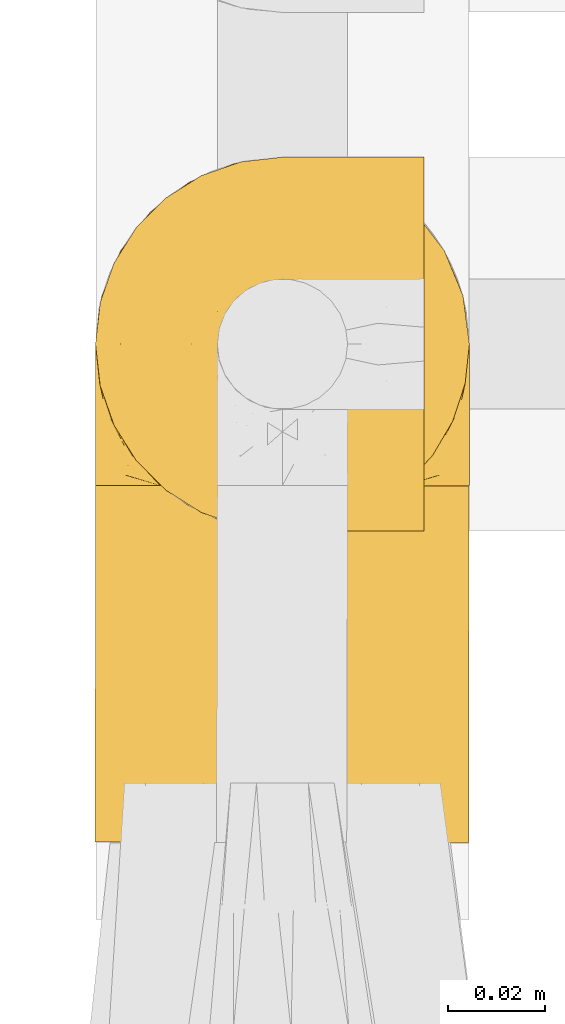
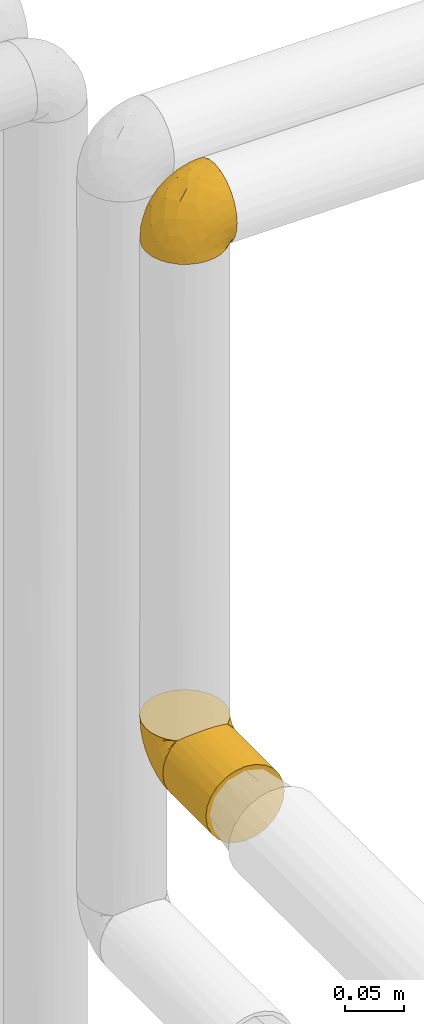
# One storey, part 76 of 827: 3 coverings.
"""IFC2X3 building model written with IfcOpenShell, lengths in millimetres."""

from ifc_helpers import new_model, entity, si_unit, converted_unit, derived_unit, direction, frame, origin, place, context, subcontext, project, spatial, faceted_brep, element, save


model = new_model("IFC2X3")

# Units and contexts
model_context = context("Model", 3, precision=0.01, world=origin(), true_north=direction((6.12303176911189e-17, 1.0)))
body_context = subcontext(model_context, "Body", "Model", "MODEL_VIEW")
ifc_project = project(units=[si_unit("LENGTHUNIT", "METRE", prefix="MILLI"), si_unit("AREAUNIT", "SQUARE_METRE"), si_unit("VOLUMEUNIT", "CUBIC_METRE"), converted_unit("PLANEANGLEUNIT", "DEGREE", entity("IfcRatioMeasure", 0.0174532925199433), si_unit("PLANEANGLEUNIT", "RADIAN"), dimensions=[0, 0, 0, 0, 0, 0, 0]), si_unit("MASSUNIT", "GRAM", prefix="KILO"), derived_unit("MASSDENSITYUNIT", [(si_unit("MASSUNIT", "GRAM", prefix="KILO"), 1), (si_unit("LENGTHUNIT", "METRE"), -3)]), derived_unit("MOMENTOFINERTIAUNIT", [(si_unit("LENGTHUNIT", "METRE"), 4)]), si_unit("TIMEUNIT", "SECOND"), si_unit("FREQUENCYUNIT", "HERTZ"), si_unit("THERMODYNAMICTEMPERATUREUNIT", "DEGREE_CELSIUS"), derived_unit("THERMALTRANSMITTANCEUNIT", [(si_unit("MASSUNIT", "GRAM", prefix="KILO"), 1), (si_unit("THERMODYNAMICTEMPERATUREUNIT", "KELVIN"), -1), (si_unit("TIMEUNIT", "SECOND"), -3)]), derived_unit("VOLUMETRICFLOWRATEUNIT", [(si_unit("LENGTHUNIT", "METRE"), 3), (si_unit("TIMEUNIT", "SECOND"), -1)]), derived_unit("MASSFLOWRATEUNIT", [(si_unit("MASSUNIT", "GRAM", prefix="KILO"), 1), (si_unit("TIMEUNIT", "SECOND"), -1)]), derived_unit("ROTATIONALFREQUENCYUNIT", [(si_unit("TIMEUNIT", "SECOND"), -1)]), si_unit("ELECTRICCURRENTUNIT", "AMPERE"), si_unit("ELECTRICVOLTAGEUNIT", "VOLT"), si_unit("POWERUNIT", "WATT"), si_unit("FORCEUNIT", "NEWTON", prefix="KILO"), si_unit("ILLUMINANCEUNIT", "LUX"), si_unit("LUMINOUSFLUXUNIT", "LUMEN"), si_unit("LUMINOUSINTENSITYUNIT", "CANDELA"), derived_unit("USERDEFINED", [(si_unit("MASSUNIT", "GRAM", prefix="KILO"), -1), (si_unit("LENGTHUNIT", "METRE"), -2), (si_unit("TIMEUNIT", "SECOND"), 3), (si_unit("LUMINOUSFLUXUNIT", "LUMEN"), 1)]), derived_unit("LINEARVELOCITYUNIT", [(si_unit("LENGTHUNIT", "METRE"), 1), (si_unit("TIMEUNIT", "SECOND"), -1)]), si_unit("PRESSUREUNIT", "PASCAL"), derived_unit("USERDEFINED", [(si_unit("LENGTHUNIT", "METRE"), -2), (si_unit("MASSUNIT", "GRAM", prefix="KILO"), 1), (si_unit("TIMEUNIT", "SECOND"), -2)]), derived_unit("LINEARFORCEUNIT", [(si_unit("MASSUNIT", "GRAM", prefix="KILO"), 1), (si_unit("LENGTHUNIT", "METRE"), 1), (si_unit("TIMEUNIT", "SECOND"), -2), (si_unit("LENGTHUNIT", "METRE"), -1)]), derived_unit("PLANARFORCEUNIT", [(si_unit("MASSUNIT", "GRAM", prefix="KILO"), 1), (si_unit("LENGTHUNIT", "METRE"), 1), (si_unit("TIMEUNIT", "SECOND"), -2), (si_unit("LENGTHUNIT", "METRE"), -2)])], contexts=[model_context])

# Site, building, storey
site_placement = place(None, origin())
site = spatial("IfcSite", under=ifc_project, at=site_placement, CompositionType="ELEMENT")
building_placement = place(site_placement, origin())
building = spatial("IfcBuilding", under=site, at=building_placement, CompositionType="ELEMENT")
storey_placement = place(building_placement, frame((0.0, 0.0, 28200.0)))
storey = spatial("IfcBuildingStorey", under=building, at=storey_placement, Name="08", CompositionType="ELEMENT", Elevation=28200.0)

# Coverings
covering_1_placement = place(storey_placement, frame((17886.68, 11719.47, 1869.3)))
element("IfcCovering", 1, at=covering_1_placement, inside=storey, Name=":ADSK_", ObjectType=":ADSK_", PredefinedType="INSULATION", context=body_context, shape_type="Brep", body=[
    faceted_brep([(23.36, 5.41, 1.6), (16.07, 9.99, 1.6), (9.98, 16.08, 1.6), (5.4, 23.37, 1.6), (2.56, 31.49, 1.6), (1.6, 40.05, 1.6), (2.56, 48.61, 1.6), (5.41, 56.73, 1.6), (9.99, 64.02, 1.6), (16.08, 70.11, 1.6), (23.37, 74.69, 1.6), (31.49, 77.53, 1.6), (40.05, 78.5, 1.6), (48.15, 77.63, 1.6), (55.88, 75.08, 1.6), (62.9, 70.97, 1.6), (68.89, 65.47, 1.6), (68.89, 63.27, 1.6), (68.89, 61.53, 1.6), (68.89, 59.57, 1.6), (68.89, 57.6, 1.6), (68.89, 55.63, 1.6), (68.89, 53.67, 1.6), (68.89, 51.7, 1.6), (68.89, 49.73, 1.6), (68.89, 47.54, 1.6), (68.89, 45.34, 1.6), (68.89, 43.15, 1.6), (68.89, 40.96, 1.6), (68.89, 38.76, 1.6), (68.89, 36.57, 1.6), (68.89, 34.37, 1.6), (68.89, 32.18, 1.6), (68.89, 29.98, 1.6), (68.89, 27.79, 1.6), (68.89, 25.6, 1.6), (68.89, 23.4, 1.6), (68.89, 21.21, 1.6), (68.89, 19.01, 1.6), (68.89, 16.82, 1.6), (68.89, 14.62, 1.6), (62.89, 9.12, 1.6), (55.86, 5.0, 1.6), (48.13, 2.46, 1.6), (40.05, 1.6, 1.6), (31.49, 2.56, 1.6), (69.15, 65.47, 1.85), (69.15, 70.97, 7.85), (69.15, 75.09, 14.87), (69.15, 77.63, 22.6), (69.15, 78.5, 30.7), (69.15, 77.19, 40.65), (69.15, 73.34, 49.92), (69.15, 67.23, 57.88), (69.15, 59.27, 63.99), (69.15, 50.0, 67.84), (69.15, 40.05, 69.15), (69.15, 30.09, 67.84), (69.15, 20.82, 63.99), (69.15, 12.86, 57.88), (69.15, 6.75, 49.92), (69.15, 2.91, 40.65), (69.15, 1.6, 30.7), (69.15, 2.46, 22.6), (69.15, 5.0, 14.87), (69.15, 9.12, 7.85), (69.15, 14.62, 1.85), (69.15, 16.82, 1.85), (69.15, 17.8, 1.85), (69.15, 19.39, 1.85), (69.15, 20.98, 1.85), (69.15, 22.57, 1.85), (69.15, 24.16, 1.85), (69.15, 25.75, 1.85), (69.15, 27.33, 1.85), (69.15, 28.92, 1.85), (69.15, 30.51, 1.85), (69.15, 32.1, 1.85), (69.15, 33.69, 1.85), (69.15, 35.28, 1.85), (69.15, 36.87, 1.85), (69.15, 38.46, 1.85), (69.15, 40.05, 1.85), (69.15, 41.63, 1.85), (69.15, 43.22, 1.85), (69.15, 44.81, 1.85), (69.15, 46.4, 1.85), (69.15, 47.99, 1.85), (69.15, 49.58, 1.85), (69.15, 51.17, 1.85), (69.15, 52.76, 1.85), (69.15, 54.72, 1.85), (69.15, 56.69, 1.85), (69.15, 58.88, 1.85), (69.15, 61.08, 1.85), (69.15, 63.27, 1.85), (68.96, 37.77, 1.77), (68.97, 36.07, 1.78), (68.97, 32.96, 1.77), (68.97, 31.36, 1.77), (68.95, 56.52, 1.76), (68.96, 54.96, 1.77), (68.98, 18.75, 1.79), (68.97, 58.07, 1.78), (68.97, 50.37, 1.78), (68.98, 23.36, 1.78), (68.97, 24.95, 1.78), (68.97, 42.43, 1.78), (68.94, 15.97, 1.74), (68.98, 51.96, 1.78), (68.98, 53.47, 1.78), (68.96, 48.63, 1.77), (68.97, 63.93, 1.78), (68.98, 40.93, 1.78), (68.98, 29.72, 1.78), (68.97, 62.4, 1.77), (68.96, 60.92, 1.77), (68.97, 17.31, 1.77), (68.97, 21.74, 1.78), (68.98, 34.56, 1.78), (68.96, 20.18, 1.77), (68.97, 14.62, 1.77), (68.94, 14.62, 1.72), (68.92, 14.62, 1.66), (68.97, 65.47, 1.77), (69.02, 65.47, 1.8), (69.08, 65.47, 1.82), (68.98, 59.5, 1.79), (68.97, 47.1, 1.78), (68.98, 45.61, 1.79), (68.97, 28.18, 1.78), (69.08, 14.62, 1.82), (69.02, 14.62, 1.8), (68.96, 26.61, 1.76), (68.92, 65.47, 1.66), (68.94, 65.47, 1.72), (68.97, 39.32, 1.78), (68.96, 44.12, 1.77), (67.02, 72.26, 9.41), (63.33, 76.57, 17.65), (64.61, 71.77, 7.41), (49.27, 78.5, 21.47), (51.4, 77.9, 15.21), (43.94, 78.5, 16.15), (61.87, 78.5, 28.75), (61.54, 75.52, 13.67), (57.95, 76.13, 12.79), (56.12, 77.81, 19.18), (63.4, 78.5, 29.16), (65.41, 72.4, 9.04), (53.1, 76.56, 7.41), (63.04, 71.77, 5.74), (61.33, 72.25, 3.72), (41.99, 78.5, 8.87), (54.6, 78.5, 26.8), (56.6, 75.75, 9.53), (41.58, 78.5, 7.34), (13.72, 50.46, 37.63), (5.82, 52.75, 17.92), (6.74, 40.05, 27.45), (58.82, 77.7, 37.01), (51.58, 77.66, 34.22), (42.09, 71.02, 45.87), (46.12, 63.45, 56.57), (55.56, 70.55, 52.31), (52.38, 75.57, 42.07), (61.54, 75.57, 44.74), (23.76, 72.61, 21.49), (20.5, 72.61, 11.02), (14.64, 67.24, 15.64), (41.77, 77.74, 26.02), (16.28, 57.43, 36.59), (49.4, 47.19, 65.49), (52.34, 54.76, 63.99), (4.3, 40.05, 15.2), (58.67, 63.45, 60.27), (25.26, 60.1, 45.25), (20.17, 63.72, 35.21), (34.7, 76.83, 22.52), (28.67, 76.34, 12.03), (8.62, 60.51, 13.32), (33.37, 72.59, 35.9), (41.35, 76.05, 33.87), (17.15, 66.15, 25.73), (12.68, 60.51, 26.34), (21.47, 51.88, 46.78), (41.11, 55.34, 59.54), (37.53, 48.67, 60.18), (30.64, 53.89, 53.93), (26.66, 46.73, 53.36), (21.38, 40.05, 49.36), (14.06, 40.05, 38.4), (55.54, 40.05, 66.44), (35.17, 63.95, 50.09), (29.04, 67.24, 41.08), (24.34, 69.62, 31.14), (29.33, 73.6, 28.19), (43.3, 40.05, 64.0), (32.34, 40.05, 56.68), (57.75, 4.52, 43.9), (49.41, 32.72, 65.46), (27.85, 27.18, 52.22), (13.7, 29.63, 37.61), (14.63, 12.86, 15.64), (8.61, 19.59, 13.31), (48.85, 9.54, 50.02), (54.13, 16.64, 59.28), (37.84, 17.48, 53.05), (23.75, 7.49, 21.48), (20.49, 7.49, 11.01), (28.66, 3.75, 12.03), (20.83, 20.75, 41.02), (55.15, 2.33, 35.39), (54.6, 1.6, 26.8), (61.87, 1.6, 28.75), (41.58, 1.6, 7.34), (57.58, 26.94, 65.81), (59.91, 9.54, 53.28), (36.94, 31.21, 59.8), (45.72, 25.33, 61.82), (5.82, 27.35, 17.91), (37.91, 8.17, 41.4), (50.18, 4.3, 40.48), (12.67, 19.59, 26.34), (49.29, 2.23, 31.68), (42.64, 2.45, 27.68), (43.94, 1.6, 16.15), (49.27, 1.6, 21.47), (19.45, 12.86, 28.05), (34.7, 3.27, 22.54), (41.99, 1.6, 8.87), (62.29, 2.29, 37.3), (29.01, 12.86, 41.07), (31.47, 6.89, 32.24), (37.18, 12.43, 47.4), (43.45, 4.1, 35.77), (63.33, 3.53, 17.65), (67.23, 6.88, 11.06), (66.07, 8.16, 8.55), (65.22, 9.02, 6.63), (61.99, 5.0, 12.77), (57.95, 3.96, 12.79), (53.09, 3.52, 7.41), (56.84, 2.4, 18.97), (61.33, 7.83, 3.72), (63.06, 8.32, 5.76), (51.41, 2.19, 15.21), (56.61, 4.34, 9.52)], [[[0, 1, 2, 3, 4, 5, 6, 7, 8, 9, 10, 11, 12, 13, 14, 15, 16, 17, 18, 19, 20, 21, 22, 23, 24, 25, 26, 27, 28, 29, 30, 31, 32, 33, 34, 35, 36, 37, 38, 39, 40, 41, 42, 43, 44, 45]], [[46, 47, 48, 49, 50, 51, 52, 53, 54, 55, 56, 57, 58, 59, 60, 61, 62, 63, 64, 65, 66, 67, 68, 69, 70, 71, 72, 73, 74, 75, 76, 77, 78, 79, 80, 81, 82, 83, 84, 85, 86, 87, 88, 89, 90, 91, 92, 93, 94, 95]], [[96, 97, 30]], [[98, 77, 99]], [[100, 101, 21]], [[69, 68, 102]], [[20, 19, 103]], [[24, 23, 104]], [[20, 103, 100]], [[72, 105, 106]], [[84, 83, 107]], [[89, 88, 104]], [[108, 67, 66]], [[109, 110, 90]], [[111, 25, 24]], [[112, 17, 16]], [[82, 113, 83]], [[109, 23, 22]], [[114, 76, 75]], [[105, 36, 106]], [[104, 111, 24]], [[18, 115, 116]], [[97, 96, 80]], [[67, 108, 117]], [[105, 71, 118]], [[31, 97, 119]], [[102, 120, 69]], [[108, 121, 122, 123, 40]], [[112, 95, 115]], [[17, 115, 18]], [[94, 116, 115]], [[117, 68, 67]], [[38, 117, 39]], [[112, 124, 125, 126, 46]], [[17, 112, 115]], [[70, 120, 118]], [[39, 117, 108]], [[120, 38, 37]], [[120, 37, 118]], [[120, 70, 69]], [[116, 94, 127]], [[128, 86, 129]], [[117, 38, 102]], [[74, 130, 75]], [[99, 33, 32]], [[115, 95, 94]], [[39, 108, 40]], [[108, 66, 131, 132, 121]], [[105, 72, 71]], [[118, 37, 36]], [[71, 70, 118]], [[35, 106, 36]], [[36, 105, 118]], [[35, 133, 106]], [[74, 73, 133]], [[106, 133, 73]], [[99, 114, 33]], [[133, 35, 34]], [[73, 72, 106]], [[95, 112, 46]], [[112, 16, 134, 135, 124]], [[130, 114, 75]], [[99, 76, 114]], [[114, 130, 33]], [[34, 33, 130]], [[78, 77, 98]], [[98, 119, 78]], [[130, 133, 34]], [[133, 130, 74]], [[79, 97, 80]], [[98, 99, 32]], [[98, 32, 31]], [[77, 76, 99]], [[97, 79, 119]], [[136, 96, 29]], [[30, 97, 31]], [[136, 29, 28]], [[81, 80, 96]], [[29, 96, 30]], [[31, 119, 98]], [[119, 79, 78]], [[96, 136, 81]], [[82, 81, 136]], [[113, 107, 83]], [[84, 107, 137]], [[107, 27, 137]], [[113, 28, 107]], [[27, 107, 28]], [[85, 84, 137]], [[137, 27, 26]], [[113, 136, 28]], [[136, 113, 82]], [[109, 89, 104]], [[86, 85, 129]], [[89, 109, 90]], [[111, 87, 128]], [[26, 129, 137]], [[88, 111, 104]], [[25, 111, 128]], [[22, 110, 109]], [[23, 109, 104]], [[110, 91, 90]], [[100, 92, 101]], [[110, 22, 101]], [[91, 110, 101]], [[116, 19, 18]], [[111, 88, 87]], [[127, 103, 19]], [[25, 128, 26]], [[86, 128, 87]], [[128, 129, 26]], [[137, 129, 85]], [[120, 102, 38]], [[117, 102, 68]], [[91, 101, 92]], [[21, 101, 22]], [[93, 92, 103]], [[100, 21, 20]], [[100, 103, 92]], [[127, 93, 103]], [[93, 127, 94]], [[116, 127, 19]], [[126, 138, 47]], [[48, 138, 139]], [[140, 125, 124]], [[141, 142, 143]], [[144, 49, 139]], [[145, 140, 146]], [[48, 139, 49]], [[139, 145, 147]], [[49, 144, 148, 50]], [[126, 125, 149]], [[14, 13, 150]], [[151, 146, 140]], [[149, 140, 145]], [[152, 151, 135]], [[152, 14, 150]], [[16, 15, 134]], [[13, 153, 150]], [[124, 151, 140]], [[141, 147, 142]], [[14, 152, 15]], [[15, 152, 134]], [[47, 46, 126]], [[139, 154, 144]], [[138, 48, 47]], [[125, 140, 149]], [[135, 134, 152]], [[146, 155, 142]], [[145, 146, 147]], [[149, 139, 138]], [[147, 141, 154]], [[147, 146, 142]], [[139, 147, 154]], [[139, 149, 145]], [[149, 138, 126]], [[155, 146, 151]], [[150, 143, 142]], [[152, 155, 151]], [[150, 142, 155]], [[13, 12, 156, 153]], [[153, 143, 150]], [[152, 150, 155]], [[151, 124, 135]], [[157, 158, 159]], [[160, 154, 161]], [[162, 163, 164]], [[165, 166, 160]], [[167, 168, 169]], [[141, 170, 161]], [[156, 12, 11]], [[158, 157, 171]], [[172, 55, 173]], [[158, 6, 174]], [[175, 54, 53]], [[52, 166, 164]], [[52, 164, 53]], [[54, 175, 173]], [[166, 52, 51]], [[176, 177, 171]], [[178, 143, 179]], [[156, 11, 179]], [[8, 7, 180]], [[169, 9, 8]], [[179, 143, 153, 156]], [[179, 11, 10]], [[168, 179, 10]], [[181, 162, 182]], [[179, 167, 178]], [[183, 184, 177]], [[183, 169, 184]], [[176, 171, 185]], [[172, 186, 187]], [[158, 7, 6]], [[159, 158, 174]], [[184, 180, 158]], [[54, 173, 55]], [[180, 169, 8]], [[188, 189, 187]], [[9, 168, 10]], [[186, 188, 187]], [[190, 157, 159, 191]], [[55, 172, 192]], [[176, 193, 194]], [[161, 170, 182]], [[162, 164, 165]], [[175, 164, 163]], [[51, 50, 148]], [[167, 195, 196]], [[178, 182, 170]], [[6, 5, 174]], [[158, 180, 7]], [[169, 180, 184]], [[169, 168, 9]], [[179, 168, 167]], [[182, 162, 165]], [[162, 194, 193]], [[161, 165, 160]], [[195, 181, 196]], [[192, 172, 197]], [[192, 56, 55]], [[189, 190, 198]], [[198, 197, 187]], [[172, 187, 197]], [[185, 189, 188]], [[198, 187, 189]], [[186, 172, 173]], [[173, 163, 186]], [[193, 186, 163]], [[176, 185, 188]], [[185, 157, 190]], [[188, 186, 193]], [[177, 176, 194]], [[188, 193, 176]], [[162, 193, 163]], [[195, 177, 194]], [[171, 177, 184]], [[181, 195, 194]], [[183, 167, 169]], [[162, 181, 194]], [[196, 182, 178]], [[158, 171, 184]], [[171, 157, 185]], [[177, 195, 183]], [[167, 183, 195]], [[182, 196, 181]], [[178, 170, 143]], [[178, 167, 196]], [[164, 175, 53]], [[173, 175, 163]], [[160, 51, 148]], [[164, 166, 165]], [[51, 160, 166]], [[160, 148, 144, 154]], [[141, 161, 154]], [[182, 165, 161]], [[190, 189, 185]], [[143, 170, 141]], [[60, 199, 61]], [[197, 200, 192]], [[201, 190, 202]], [[200, 57, 192]], [[203, 204, 2]], [[205, 206, 207]], [[208, 209, 210]], [[211, 207, 201]], [[212, 213, 214]], [[45, 215, 210]], [[216, 206, 58]], [[45, 44, 215]], [[59, 217, 60]], [[60, 217, 199]], [[0, 45, 210]], [[218, 201, 219]], [[202, 159, 220]], [[205, 221, 222]], [[223, 204, 203]], [[1, 203, 2]], [[57, 200, 216]], [[220, 3, 204]], [[220, 174, 4]], [[1, 0, 209]], [[212, 224, 213]], [[225, 226, 227]], [[228, 223, 203]], [[208, 210, 229]], [[210, 226, 229]], [[3, 220, 4]], [[58, 206, 59]], [[209, 203, 1]], [[202, 220, 223]], [[228, 203, 208]], [[202, 211, 201]], [[3, 2, 204]], [[202, 190, 191, 159]], [[210, 215, 230, 226]], [[199, 212, 231]], [[232, 233, 221]], [[233, 208, 229]], [[207, 206, 219]], [[217, 206, 205]], [[227, 224, 225]], [[233, 232, 228]], [[201, 207, 219]], [[234, 232, 221]], [[218, 219, 200]], [[202, 223, 211]], [[174, 220, 159]], [[174, 5, 4]], [[61, 231, 62]], [[220, 204, 223]], [[210, 209, 0]], [[203, 209, 208]], [[225, 233, 229]], [[224, 227, 213]], [[221, 233, 235]], [[57, 56, 192]], [[198, 218, 197]], [[200, 219, 216]], [[201, 198, 190]], [[197, 218, 200]], [[198, 201, 218]], [[206, 216, 219]], [[58, 57, 216]], [[231, 212, 214]], [[222, 212, 199]], [[228, 211, 223]], [[207, 211, 232]], [[62, 231, 214]], [[199, 231, 61]], [[233, 228, 208]], [[211, 228, 232]], [[222, 221, 235]], [[234, 205, 207]], [[206, 217, 59]], [[199, 217, 205]], [[205, 222, 199]], [[224, 222, 235]], [[222, 224, 212]], [[224, 235, 225]], [[233, 225, 235]], [[226, 225, 229]], [[205, 234, 221]], [[207, 232, 234]], [[63, 214, 236]], [[214, 213, 236]], [[214, 63, 62]], [[237, 236, 238]], [[238, 132, 131]], [[236, 237, 64]], [[239, 240, 241]], [[63, 236, 64]], [[131, 66, 65]], [[237, 131, 65]], [[242, 230, 43]], [[237, 65, 64]], [[239, 121, 132]], [[42, 242, 43]], [[241, 240, 243]], [[41, 123, 244]], [[43, 230, 215, 44]], [[244, 122, 245]], [[227, 246, 243]], [[241, 247, 245]], [[121, 239, 245]], [[41, 40, 123]], [[132, 238, 239]], [[244, 42, 41]], [[131, 237, 238]], [[240, 239, 238]], [[245, 239, 241]], [[247, 241, 246]], [[247, 244, 245]], [[238, 236, 240]], [[243, 236, 213]], [[236, 243, 240]], [[227, 226, 246]], [[243, 213, 227]], [[242, 246, 226]], [[243, 246, 241]], [[246, 242, 247]], [[244, 247, 242]], [[242, 226, 230]], [[42, 244, 242]], [[122, 244, 123]], [[122, 121, 245]]]),
])
covering_2_placement = place(storey_placement, frame((17886.55, 11656.92, 1308.25)))
element("IfcCovering", 2, at=covering_2_placement, inside=storey, Name=":ADSK_", ObjectType=":ADSK_", PredefinedType="INSULATION", context=body_context, shape_type="Brep", body=[
    faceted_brep([(13.02, 73.56, 12.84), (6.91, 73.57, 20.8), (3.08, 73.58, 30.06), (1.77, 73.58, 40.0), (2.65, 73.58, 48.19), (5.26, 73.57, 55.99), (9.46, 73.56, 63.05), (15.08, 73.55, 69.06), (65.19, 73.43, 69.13), (70.83, 73.42, 63.11), (75.06, 73.41, 56.03), (77.68, 73.4, 48.21), (78.57, 73.4, 40.0), (77.26, 73.4, 30.06), (73.42, 73.41, 20.8), (67.32, 73.43, 12.84), (59.37, 73.45, 6.74), (50.11, 73.47, 2.9), (40.17, 73.49, 1.6), (30.23, 73.51, 2.9), (20.97, 73.54, 6.74), (2.9, 0.18, 30.06), (6.74, 0.17, 20.8), (12.84, 0.15, 12.84), (20.8, 0.14, 6.74), (30.06, 0.11, 2.9), (40.0, 0.09, 1.6), (49.93, 0.07, 2.9), (59.2, 0.05, 6.74), (67.15, 0.03, 12.84), (73.25, 0.01, 20.8), (77.09, 0.0, 30.06), (78.4, 0.0, 40.0), (77.09, 0.0, 49.93), (73.25, 0.01, 59.2), (67.15, 0.03, 67.15), (59.2, 0.05, 73.25), (49.93, 0.07, 77.09), (40.0, 0.09, 78.4), (30.06, 0.11, 77.09), (20.8, 0.14, 73.25), (12.84, 0.15, 67.15), (6.74, 0.17, 59.2), (2.9, 0.18, 49.93), (1.6, 0.18, 40.0), (26.77, 66.61, 75.99), (33.35, 64.81, 77.79), (40.15, 64.19, 78.4), (20.61, 69.56, 73.05), (46.92, 64.79, 77.79), (53.49, 66.57, 76.0), (59.64, 69.48, 73.08)], [[[0, 1, 2, 3, 4, 5, 6, 7, 8, 9, 10, 11, 12, 13, 14, 15, 16, 17, 18, 19, 20]], [[21, 22, 23, 24, 25, 26, 27, 28, 29, 30, 31, 32, 33, 34, 35, 36, 37, 38, 39, 40, 41, 42, 43, 44]], [[31, 30, 14, 13]], [[32, 31, 13, 12]], [[15, 14, 30, 29]], [[17, 16, 28, 27]], [[18, 17, 27, 26]], [[29, 28, 16, 15]], [[19, 18, 26, 25]], [[20, 19, 25, 24]], [[24, 23, 0, 20]], [[2, 1, 22, 21]], [[3, 2, 21, 44]], [[23, 22, 1, 0]], [[4, 44, 43]], [[5, 43, 42]], [[6, 42, 41]], [[3, 44, 4]], [[4, 43, 5]], [[42, 6, 5]], [[41, 7, 6]], [[45, 40, 39]], [[39, 38, 46]], [[47, 46, 38]], [[48, 7, 40]], [[46, 45, 39]], [[48, 40, 45]], [[40, 7, 41]], [[49, 47, 38]], [[49, 38, 37]], [[50, 37, 36]], [[50, 49, 37]], [[8, 51, 36]], [[50, 36, 51]], [[36, 35, 8]], [[9, 35, 34]], [[10, 34, 33]], [[11, 33, 32]], [[9, 34, 10]], [[10, 33, 11]], [[32, 12, 11]], [[35, 9, 8]], [[48, 45, 46, 47, 49, 50, 51, 8, 7]]]),
])
covering_3_placement = place(storey_placement, frame((17886.68, 11728.82, 1308.2)))
element("IfcCovering", 3, at=covering_3_placement, inside=storey, Name=":ADSK_", ObjectType=":ADSK_", PredefinedType="INSULATION", context=body_context, shape_type="Brep", body=[
    faceted_brep([(5.41, 1.6, 23.36), (9.99, 1.6, 16.07), (16.08, 1.6, 9.98), (23.37, 1.6, 5.4), (31.49, 1.6, 2.56), (40.05, 1.6, 1.6), (48.61, 1.6, 2.56), (56.73, 1.6, 5.41), (64.02, 1.6, 9.99), (70.11, 1.6, 16.08), (74.69, 1.6, 23.37), (77.53, 1.6, 31.49), (78.5, 1.6, 40.05), (77.63, 1.6, 48.15), (75.08, 1.6, 55.88), (70.97, 1.6, 62.9), (65.47, 1.6, 68.89), (63.27, 1.6, 68.89), (61.53, 1.6, 68.89), (59.57, 1.6, 68.89), (57.6, 1.6, 68.89), (55.63, 1.6, 68.89), (53.67, 1.6, 68.89), (51.7, 1.6, 68.89), (49.73, 1.6, 68.89), (47.54, 1.6, 68.89), (45.34, 1.6, 68.89), (43.15, 1.6, 68.89), (40.96, 1.6, 68.89), (38.76, 1.6, 68.89), (36.57, 1.6, 68.89), (34.37, 1.6, 68.89), (32.18, 1.6, 68.89), (29.98, 1.6, 68.89), (27.79, 1.6, 68.89), (25.6, 1.6, 68.89), (23.4, 1.6, 68.89), (21.21, 1.6, 68.89), (19.01, 1.6, 68.89), (16.82, 1.6, 68.89), (14.62, 1.6, 68.89), (9.12, 1.6, 62.89), (5.0, 1.6, 55.86), (2.46, 1.6, 48.13), (1.6, 1.6, 40.05), (2.56, 1.6, 31.49), (65.47, 1.85, 69.15), (70.97, 7.85, 69.15), (75.09, 14.87, 69.15), (77.63, 22.6, 69.15), (78.5, 30.7, 69.15), (77.19, 40.65, 69.15), (73.34, 49.92, 69.15), (67.23, 57.88, 69.15), (59.27, 63.99, 69.15), (50.0, 67.84, 69.15), (40.05, 69.15, 69.15), (30.09, 67.84, 69.15), (20.82, 63.99, 69.15), (12.86, 57.88, 69.15), (6.75, 49.92, 69.15), (2.91, 40.65, 69.15), (1.6, 30.7, 69.15), (2.46, 22.6, 69.15), (5.0, 14.87, 69.15), (9.12, 7.85, 69.15), (14.62, 1.85, 69.15), (16.82, 1.85, 69.15), (17.8, 1.85, 69.15), (19.39, 1.85, 69.15), (20.98, 1.85, 69.15), (22.57, 1.85, 69.15), (24.16, 1.85, 69.15), (25.75, 1.85, 69.15), (27.33, 1.85, 69.15), (28.92, 1.85, 69.15), (30.51, 1.85, 69.15), (32.1, 1.85, 69.15), (33.69, 1.85, 69.15), (35.28, 1.85, 69.15), (36.87, 1.85, 69.15), (38.46, 1.85, 69.15), (40.05, 1.85, 69.15), (41.63, 1.85, 69.15), (43.22, 1.85, 69.15), (44.81, 1.85, 69.15), (46.4, 1.85, 69.15), (47.99, 1.85, 69.15), (49.58, 1.85, 69.15), (51.17, 1.85, 69.15), (52.76, 1.85, 69.15), (54.72, 1.85, 69.15), (56.69, 1.85, 69.15), (58.88, 1.85, 69.15), (61.08, 1.85, 69.15), (63.27, 1.85, 69.15), (37.77, 1.77, 68.96), (36.07, 1.78, 68.97), (32.96, 1.77, 68.97), (31.36, 1.77, 68.97), (56.52, 1.76, 68.95), (54.96, 1.77, 68.96), (18.75, 1.79, 68.98), (58.07, 1.78, 68.97), (50.37, 1.78, 68.97), (23.36, 1.78, 68.98), (24.95, 1.78, 68.97), (42.43, 1.78, 68.97), (15.97, 1.74, 68.94), (51.96, 1.78, 68.98), (53.47, 1.78, 68.98), (48.63, 1.77, 68.96), (63.93, 1.78, 68.97), (40.93, 1.78, 68.98), (29.72, 1.78, 68.98), (62.4, 1.77, 68.97), (60.92, 1.77, 68.96), (17.31, 1.77, 68.97), (21.74, 1.78, 68.97), (34.56, 1.78, 68.98), (20.18, 1.77, 68.96), (14.62, 1.77, 68.97), (14.62, 1.72, 68.94), (14.62, 1.66, 68.92), (65.47, 1.77, 68.97), (65.47, 1.8, 69.02), (59.5, 1.79, 68.98), (47.1, 1.78, 68.97), (45.61, 1.79, 68.98), (28.18, 1.78, 68.97), (14.62, 1.82, 69.08), (26.61, 1.76, 68.96), (65.47, 1.66, 68.92), (65.47, 1.72, 68.94), (39.32, 1.78, 68.97), (44.12, 1.77, 68.96), (65.47, 1.82, 69.08), (72.26, 9.41, 67.02), (76.57, 17.65, 63.33), (71.77, 7.41, 64.61), (77.9, 15.21, 51.4), (76.56, 7.41, 53.1), (78.5, 16.15, 43.94), (78.5, 28.75, 61.87), (75.52, 13.67, 61.54), (76.13, 12.79, 57.95), (77.81, 19.18, 56.12), (78.5, 29.16, 63.4), (72.4, 9.04, 65.41), (71.77, 5.74, 63.04), (72.25, 3.72, 61.33), (78.5, 8.87, 41.99), (78.5, 21.47, 49.27), (78.5, 26.8, 54.6), (75.75, 9.53, 56.6), (78.5, 7.34, 41.58), (50.46, 37.63, 13.72), (52.75, 17.92, 5.82), (40.05, 27.45, 6.74), (77.7, 37.01, 58.82), (77.66, 34.22, 51.58), (71.02, 45.87, 42.09), (63.45, 56.57, 46.12), (70.55, 52.31, 55.56), (75.57, 42.07, 52.38), (75.57, 44.74, 61.54), (72.61, 21.49, 23.76), (72.61, 11.02, 20.5), (67.24, 15.64, 14.64), (77.74, 26.02, 41.77), (57.43, 36.59, 16.28), (47.19, 65.49, 49.4), (54.76, 63.99, 52.34), (40.05, 15.2, 4.3), (63.45, 60.27, 58.67), (60.1, 45.25, 25.26), (63.72, 35.21, 20.17), (76.83, 22.52, 34.7), (76.34, 12.03, 28.67), (60.51, 13.32, 8.62), (72.59, 35.9, 33.37), (76.05, 33.87, 41.35), (66.15, 25.73, 17.15), (60.51, 26.34, 12.68), (51.88, 46.78, 21.47), (55.34, 59.54, 41.11), (48.67, 60.18, 37.53), (53.89, 53.93, 30.64), (46.73, 53.36, 26.66), (40.05, 49.36, 21.38), (40.05, 38.4, 14.06), (40.05, 66.44, 55.54), (63.95, 50.09, 35.17), (67.24, 41.08, 29.04), (69.62, 31.14, 24.34), (73.6, 28.19, 29.33), (40.05, 64.0, 43.3), (40.05, 56.68, 32.34), (4.52, 43.9, 57.75), (32.72, 65.46, 49.41), (27.18, 52.22, 27.85), (29.63, 37.61, 13.7), (12.86, 15.64, 14.63), (19.59, 13.31, 8.61), (9.54, 50.02, 48.85), (16.64, 59.28, 54.13), (17.48, 53.05, 37.84), (7.49, 21.48, 23.75), (7.49, 11.01, 20.49), (3.75, 12.03, 28.66), (20.75, 41.02, 20.83), (2.33, 35.39, 55.15), (1.6, 26.8, 54.6), (1.6, 28.75, 61.87), (1.6, 7.34, 41.58), (26.94, 65.81, 57.58), (9.54, 53.28, 59.91), (31.21, 59.8, 36.94), (25.33, 61.82, 45.72), (27.35, 17.91, 5.82), (8.17, 41.4, 37.91), (4.3, 40.48, 50.18), (19.59, 26.34, 12.67), (2.23, 31.68, 49.29), (2.45, 27.68, 42.64), (1.6, 16.15, 43.94), (1.6, 21.47, 49.27), (12.86, 28.05, 19.45), (3.27, 22.54, 34.7), (1.6, 8.87, 41.99), (2.29, 37.3, 62.29), (12.86, 41.07, 29.01), (6.89, 32.24, 31.47), (12.43, 47.4, 37.18), (4.1, 35.77, 43.45), (3.53, 17.65, 63.33), (6.88, 11.06, 67.23), (8.16, 8.55, 66.07), (14.62, 1.8, 69.02), (9.02, 6.63, 65.22), (5.0, 12.77, 61.99), (3.96, 12.79, 57.95), (3.52, 7.41, 53.09), (2.4, 18.97, 56.84), (7.83, 3.72, 61.33), (8.32, 5.76, 63.06), (2.19, 15.21, 51.41), (4.34, 9.52, 56.61)], [[[0, 1, 2, 3, 4, 5, 6, 7, 8, 9, 10, 11, 12, 13, 14, 15, 16, 17, 18, 19, 20, 21, 22, 23, 24, 25, 26, 27, 28, 29, 30, 31, 32, 33, 34, 35, 36, 37, 38, 39, 40, 41, 42, 43, 44, 45]], [[46, 47, 48, 49, 50, 51, 52, 53, 54, 55, 56, 57, 58, 59, 60, 61, 62, 63, 64, 65, 66, 67, 68, 69, 70, 71, 72, 73, 74, 75, 76, 77, 78, 79, 80, 81, 82, 83, 84, 85, 86, 87, 88, 89, 90, 91, 92, 93, 94, 95]], [[96, 97, 30]], [[98, 77, 99]], [[100, 101, 21]], [[69, 68, 102]], [[20, 19, 103]], [[24, 23, 104]], [[20, 103, 100]], [[72, 105, 106]], [[84, 83, 107]], [[89, 88, 104]], [[108, 67, 66]], [[109, 110, 90]], [[111, 25, 24]], [[112, 17, 16]], [[82, 113, 83]], [[109, 23, 22]], [[114, 76, 75]], [[105, 36, 106]], [[104, 111, 24]], [[18, 115, 116]], [[97, 96, 80]], [[67, 108, 117]], [[105, 71, 118]], [[31, 97, 119]], [[102, 120, 69]], [[108, 121, 122, 123, 40]], [[112, 95, 115]], [[17, 115, 18]], [[94, 116, 115]], [[117, 68, 67]], [[38, 117, 39]], [[112, 124, 125]], [[17, 112, 115]], [[70, 120, 118]], [[39, 117, 108]], [[120, 38, 37]], [[120, 37, 118]], [[120, 70, 69]], [[116, 94, 126]], [[127, 86, 128]], [[117, 38, 102]], [[74, 129, 75]], [[99, 33, 32]], [[115, 95, 94]], [[39, 108, 40]], [[108, 66, 130]], [[105, 72, 71]], [[118, 37, 36]], [[71, 70, 118]], [[35, 106, 36]], [[36, 105, 118]], [[35, 131, 106]], [[74, 73, 131]], [[106, 131, 73]], [[99, 114, 33]], [[131, 35, 34]], [[73, 72, 106]], [[95, 112, 46]], [[112, 16, 132, 133, 124]], [[129, 114, 75]], [[99, 76, 114]], [[114, 129, 33]], [[34, 33, 129]], [[78, 77, 98]], [[98, 119, 78]], [[129, 131, 34]], [[131, 129, 74]], [[79, 97, 80]], [[98, 99, 32]], [[98, 32, 31]], [[77, 76, 99]], [[97, 79, 119]], [[134, 96, 29]], [[30, 97, 31]], [[134, 29, 28]], [[81, 80, 96]], [[29, 96, 30]], [[31, 119, 98]], [[119, 79, 78]], [[96, 134, 81]], [[82, 81, 134]], [[113, 107, 83]], [[84, 107, 135]], [[107, 27, 135]], [[113, 28, 107]], [[27, 107, 28]], [[85, 84, 135]], [[135, 27, 26]], [[113, 134, 28]], [[134, 113, 82]], [[109, 89, 104]], [[86, 85, 128]], [[89, 109, 90]], [[111, 87, 127]], [[26, 128, 135]], [[88, 111, 104]], [[25, 111, 127]], [[22, 110, 109]], [[23, 109, 104]], [[110, 91, 90]], [[100, 92, 101]], [[110, 22, 101]], [[91, 110, 101]], [[116, 19, 18]], [[111, 88, 87]], [[126, 103, 19]], [[25, 127, 26]], [[86, 127, 87]], [[127, 128, 26]], [[135, 128, 85]], [[120, 102, 38]], [[117, 102, 68]], [[91, 101, 92]], [[21, 101, 22]], [[93, 92, 103]], [[100, 21, 20]], [[100, 103, 92]], [[126, 93, 103]], [[93, 126, 94]], [[116, 126, 19]], [[136, 137, 47]], [[48, 137, 138]], [[139, 125, 124]], [[140, 141, 142]], [[143, 49, 138]], [[144, 139, 145]], [[48, 138, 49]], [[138, 144, 146]], [[49, 143, 147, 50]], [[136, 125, 148]], [[14, 13, 141]], [[149, 145, 139]], [[148, 139, 144]], [[150, 149, 133]], [[150, 14, 141]], [[16, 15, 132]], [[13, 151, 141]], [[124, 149, 139]], [[140, 142, 152]], [[14, 150, 15]], [[15, 150, 132]], [[47, 46, 136]], [[138, 153, 143]], [[137, 48, 47]], [[125, 139, 148]], [[133, 132, 150]], [[145, 154, 140]], [[144, 145, 146]], [[148, 138, 137]], [[146, 152, 153]], [[146, 145, 140]], [[138, 146, 153]], [[138, 148, 144]], [[148, 137, 136]], [[146, 140, 152]], [[145, 149, 154]], [[150, 154, 149]], [[141, 140, 154]], [[13, 12, 155, 151]], [[151, 142, 141]], [[150, 141, 154]], [[149, 124, 133]], [[156, 157, 158]], [[159, 153, 160]], [[161, 162, 163]], [[164, 165, 159]], [[166, 167, 168]], [[152, 169, 160]], [[155, 12, 11]], [[157, 156, 170]], [[171, 55, 172]], [[157, 6, 173]], [[174, 54, 53]], [[52, 165, 163]], [[52, 163, 53]], [[54, 174, 172]], [[165, 52, 51]], [[175, 176, 170]], [[177, 142, 178]], [[155, 11, 178]], [[8, 7, 179]], [[168, 9, 8]], [[178, 142, 151, 155]], [[178, 11, 10]], [[167, 178, 10]], [[180, 161, 181]], [[178, 166, 177]], [[182, 183, 176]], [[182, 168, 183]], [[175, 170, 184]], [[171, 185, 186]], [[157, 7, 6]], [[158, 157, 173]], [[183, 179, 157]], [[54, 172, 55]], [[179, 168, 8]], [[187, 188, 186]], [[9, 167, 10]], [[185, 187, 186]], [[189, 156, 158, 190]], [[55, 171, 191]], [[175, 192, 193]], [[160, 169, 181]], [[161, 163, 164]], [[174, 163, 162]], [[51, 50, 147]], [[166, 194, 195]], [[177, 181, 169]], [[6, 5, 173]], [[157, 179, 7]], [[168, 179, 183]], [[168, 167, 9]], [[178, 167, 166]], [[181, 161, 164]], [[161, 193, 192]], [[160, 164, 159]], [[194, 180, 195]], [[191, 171, 196]], [[191, 56, 55]], [[188, 189, 197]], [[197, 196, 186]], [[171, 186, 196]], [[184, 188, 187]], [[197, 186, 188]], [[185, 171, 172]], [[172, 162, 185]], [[192, 185, 162]], [[175, 184, 187]], [[184, 156, 189]], [[187, 185, 192]], [[176, 175, 193]], [[187, 192, 175]], [[161, 192, 162]], [[194, 176, 193]], [[170, 176, 183]], [[180, 194, 193]], [[182, 166, 168]], [[161, 180, 193]], [[195, 181, 177]], [[157, 170, 183]], [[170, 156, 184]], [[176, 194, 182]], [[166, 182, 194]], [[181, 195, 180]], [[177, 169, 142]], [[177, 166, 195]], [[163, 174, 53]], [[172, 174, 162]], [[159, 51, 147]], [[163, 165, 164]], [[51, 159, 165]], [[159, 147, 143, 153]], [[152, 160, 153]], [[181, 164, 160]], [[189, 188, 184]], [[142, 169, 152]], [[60, 198, 61]], [[196, 199, 191]], [[200, 189, 201]], [[199, 57, 191]], [[202, 203, 2]], [[204, 205, 206]], [[207, 208, 209]], [[210, 206, 200]], [[211, 212, 213]], [[45, 214, 209]], [[215, 205, 58]], [[45, 44, 214]], [[59, 216, 60]], [[60, 216, 198]], [[0, 45, 209]], [[217, 200, 218]], [[201, 158, 219]], [[204, 220, 221]], [[222, 203, 202]], [[1, 202, 2]], [[57, 199, 215]], [[219, 3, 203]], [[219, 173, 4]], [[1, 0, 208]], [[211, 223, 212]], [[224, 225, 226]], [[227, 222, 202]], [[207, 209, 228]], [[209, 225, 228]], [[3, 219, 4]], [[58, 205, 59]], [[208, 202, 1]], [[201, 219, 222]], [[227, 202, 207]], [[201, 210, 200]], [[3, 2, 203]], [[201, 189, 190, 158]], [[209, 214, 229, 225]], [[198, 211, 230]], [[231, 232, 220]], [[232, 207, 228]], [[206, 205, 218]], [[216, 205, 204]], [[226, 223, 224]], [[232, 231, 227]], [[200, 206, 218]], [[233, 231, 220]], [[217, 218, 199]], [[201, 222, 210]], [[173, 219, 158]], [[173, 5, 4]], [[61, 230, 62]], [[219, 203, 222]], [[209, 208, 0]], [[202, 208, 207]], [[224, 232, 228]], [[223, 226, 212]], [[220, 232, 234]], [[57, 56, 191]], [[197, 217, 196]], [[199, 218, 215]], [[200, 197, 189]], [[196, 217, 199]], [[197, 200, 217]], [[205, 215, 218]], [[58, 57, 215]], [[230, 211, 213]], [[221, 211, 198]], [[227, 210, 222]], [[206, 210, 231]], [[62, 230, 213]], [[198, 230, 61]], [[232, 227, 207]], [[210, 227, 231]], [[221, 220, 234]], [[233, 204, 206]], [[205, 216, 59]], [[198, 216, 204]], [[204, 221, 198]], [[223, 221, 234]], [[221, 223, 211]], [[223, 234, 224]], [[232, 224, 234]], [[225, 224, 228]], [[204, 233, 220]], [[206, 231, 233]], [[63, 213, 235]], [[213, 212, 235]], [[213, 63, 62]], [[236, 235, 237]], [[237, 238, 130]], [[235, 236, 64]], [[239, 240, 241]], [[63, 235, 64]], [[130, 66, 65]], [[236, 130, 65]], [[242, 229, 43]], [[236, 65, 64]], [[239, 121, 238]], [[42, 242, 43]], [[241, 240, 243]], [[41, 123, 244]], [[43, 229, 214, 44]], [[244, 122, 245]], [[226, 246, 243]], [[241, 243, 246]], [[121, 239, 245]], [[41, 40, 123]], [[238, 237, 239]], [[244, 42, 41]], [[130, 236, 237]], [[240, 239, 237]], [[245, 239, 241]], [[247, 241, 246]], [[247, 244, 245]], [[237, 235, 240]], [[243, 235, 212]], [[235, 243, 240]], [[225, 246, 226]], [[243, 212, 226]], [[225, 242, 246]], [[241, 247, 245]], [[246, 242, 247]], [[244, 247, 242]], [[242, 225, 229]], [[42, 244, 242]], [[122, 244, 123]], [[122, 121, 245]], [[112, 125, 136, 46]], [[108, 130, 238]], [[108, 238, 121]]]),
])

save(model, "model.ifc")
